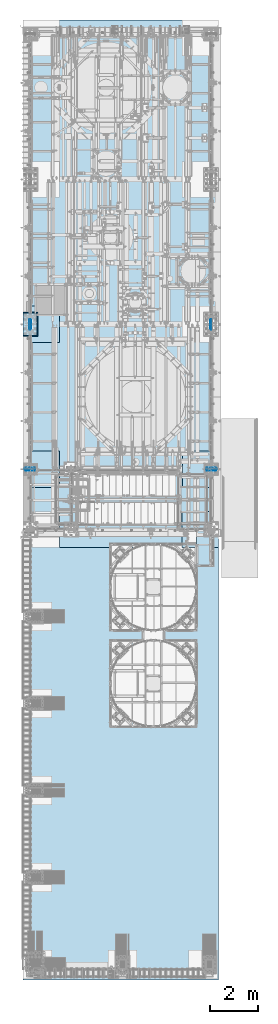
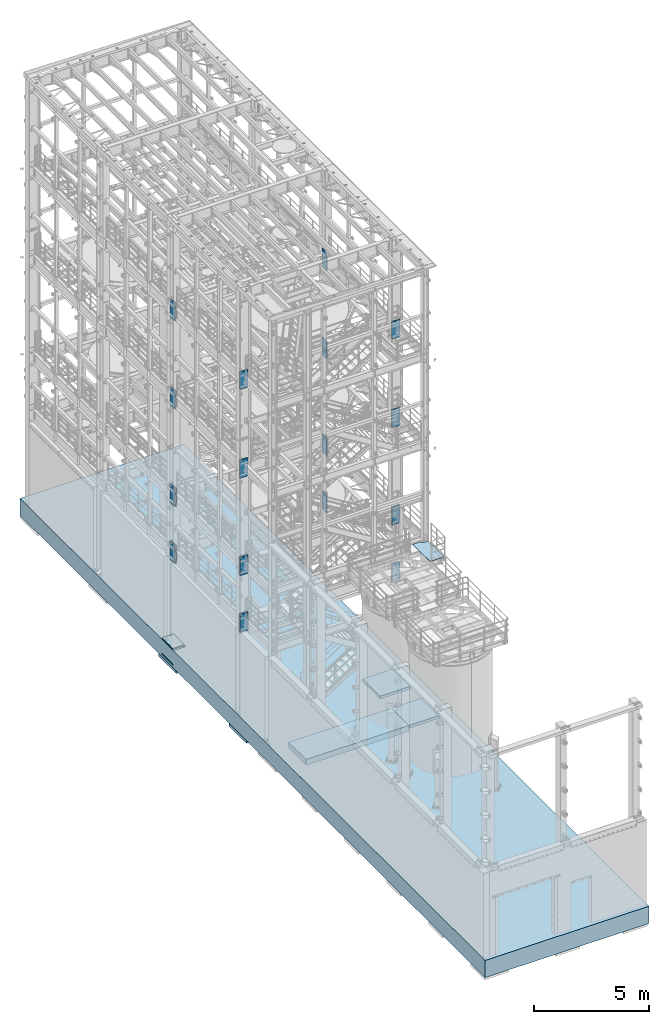
# One storey, part 1402 of 1876: 32 plates, 6 slabs, 17 elements without a shape of their own.
"""IFC2X3 building model written with IfcOpenShell, lengths in millimetres."""

from ifc_helpers import new_model, si_unit, frame, origin_with_axes, place, context, subcontext, project, spatial, faceted_brep, material, type_object, element, aggregate, save


model = new_model("IFC2X3")

# Units and contexts
model_context = context("Model", 3, precision=1e-05, world=origin_with_axes())
body_context = subcontext(model_context, "Body", "Model", "MODEL_VIEW")
ifc_project = project(units=[si_unit("LENGTHUNIT", "METRE", prefix="MILLI"), si_unit("AREAUNIT", "SQUARE_METRE"), si_unit("VOLUMEUNIT", "CUBIC_METRE"), si_unit("MASSUNIT", "GRAM", prefix="KILO"), si_unit("TIMEUNIT", "SECOND"), si_unit("PLANEANGLEUNIT", "RADIAN"), si_unit("SOLIDANGLEUNIT", "STERADIAN"), si_unit("THERMODYNAMICTEMPERATUREUNIT", "DEGREE_CELSIUS"), si_unit("LUMINOUSINTENSITYUNIT", "LUMEN")], contexts=[model_context])

# Site, building, storey
site_placement = place(None, origin_with_axes())
site = spatial("IfcSite", under=ifc_project, at=site_placement, CompositionType="ELEMENT")
building_placement = place(site_placement, origin_with_axes())
building = spatial("IfcBuilding", under=site, at=building_placement, Name="Undefined", CompositionType="ELEMENT")
storey_placement = place(building_placement, origin_with_axes())
storey = spatial("IfcBuildingStorey", under=building, at=storey_placement, Name="Undefined", CompositionType="ELEMENT", Elevation=0.0)

# Assembly, plate
assembly_1_placement = place(storey_placement, origin_with_axes())
assembly_1 = element("IfcElementAssembly", 1, at=assembly_1_placement, inside=storey, Name="GRATING", AssemblyPlace="NOTDEFINED", PredefinedType="NOTDEFINED")
ifc_material_1 = material(Name="1")
plate_type_1 = type_object("IfcPlateType", PredefinedType="NOTDEFINED")
plate_1_placement = place(assembly_1_placement, frame((6578.59999849915, -7131.05000084073, 8010.525), z_axis=(1.0, 0.0, 0.0), x_axis=(0.0, -1.0, 0.0)))
plate_1 = element("IfcPlate", 2, at=plate_1_placement, type_object=plate_type_1, material=ifc_material_1, Name="GRATING", context=body_context, shape_type="Brep", body=[
    faceted_brep([(1.23319387057563e-06, -12.6999999999998, 808.037475585938), (69.8499984741384, -12.6999999999998, 808.037475585936), (69.8499984741384, 12.6999999999998, 808.037475585936), (1.23319387057563e-06, 12.6999999999998, 808.037475585938), (69.8499984741393, -12.6999999999998, 893.762512207029), (69.8499984741393, 12.6999999999998, 893.762512207029), (123.82499694826, -12.6999999999998, 893.762512207029), (123.82499694826, 12.6999999999998, 893.762512207029), (123.824996948266, -12.6999999999998, 1123.95007324218), (123.824996948266, 12.6999999999998, 1123.95007324218), (1498.59997558596, -12.6999999999998, 1123.95007324216), (1498.59997558596, 12.6999999999998, 1123.95007324216), (1498.59997558595, -12.6999999999998, 425.451873779265), (1498.59997558595, 12.6999999999998, 425.451873779265), (584.164367675789, -12.6999999999998, 425.451873779284), (584.164367675789, 12.6999999999998, 425.451873779284), (6.49306457489729e-07, 12.6999999999998, 425.451874947612), (6.49306457489729e-07, -12.6999999999998, 425.451874947612)], [[[0, 1, 2, 3]], [[1, 4, 5, 2]], [[4, 6, 7, 5]], [[6, 8, 9, 7]], [[8, 10, 11, 9]], [[10, 12, 13, 11]], [[12, 14, 15, 13]], [[3, 2, 5, 7, 9, 11, 13, 15, 16]], [[0, 3, 16, 17]], [[12, 10, 8, 6, 4, 1, 0, 17, 14]], [[16, 15, 14, 17]]]),
])
aggregate(assembly_1, [plate_1])

# Assembly, slab
assembly_2_placement = place(storey_placement, origin_with_axes())
assembly_2 = element("IfcElementAssembly", 3, at=assembly_2_placement, inside=storey, Name="SLAB", AssemblyPlace="NOTDEFINED", PredefinedType="REINFORCEMENT_UNIT")
ifc_material_2 = material(Name="CONCRETE/3000")
slab_type_1 = type_object("IfcSlabType", PredefinedType="NOTDEFINED")
slab_1_placement = place(assembly_2_placement, frame((6388.0998046875, -6350.0, -1066.8), z_axis=(0.0, -1.0, 0.0), x_axis=(-1.0, 0.0, 0.0)))
slab_1 = element("IfcSlab", 4, at=slab_1_placement, type_object=slab_type_1, material=ifc_material_2, Name="SLAB", PredefinedType="FLOOR", context=body_context, shape_type="Brep", body=[
    faceted_brep([(0.0, -152.4, 0.0), (9.09494701772928e-13, -152.4, 1524.0), (9.09494701772928e-13, 152.4, 1524.0), (0.0, 152.4, 0.0), (5156.19970703125, -152.4, 1524.0), (5156.19970703125, 152.4, 1524.0), (5156.19970703125, -152.4, 0.0), (5156.19970703125, 152.4, 0.0)], [[[0, 1, 2, 3]], [[1, 4, 5, 2]], [[4, 6, 7, 5]], [[6, 0, 3, 7]], [[5, 7, 3, 2]], [[6, 4, 1, 0]]]),
])
aggregate(assembly_2, [slab_1])

# Assembly, plate
assembly_3_placement = place(storey_placement, origin_with_axes())
assembly_3 = element("IfcElementAssembly", 5, at=assembly_3_placement, inside=storey, Name="COLUMN", AssemblyPlace="NOTDEFINED", PredefinedType="RIGID_FRAME")
ifc_material_3 = material(Name="STEEL/A572-GR.50")
plate_type_2 = type_object("IfcPlateType", PredefinedType="NOTDEFINED")
plate_2_placement = place(assembly_3_placement, frame((-219.075, -4541.04375, 13462.0), z_axis=(1.0, 0.0, 0.0), x_axis=(0.0, 0.0, -1.0)))
plate_2 = element("IfcPlate", 6, at=plate_2_placement, type_object=plate_type_2, material=ifc_material_3, Name="PLATE", context=body_context, shape_type="Brep", body=[
    faceted_brep([(0.0, 19.0500000000002, 416.152954742277), (0.0, -19.0500000000002, 438.149993896484), (952.5, -19.0500000000002, 438.149993896484), (952.5, 19.0500000000002, 416.152954742277), (952.5, 19.0500000000002, 21.9970452577367), (0.0, 19.0500000000002, 21.9970452577367), (0.0, -19.0500000000002, 0.0), (952.5, -19.0500000000002, 0.0)], [[[0, 1, 2, 3]], [[0, 3, 4, 5]], [[1, 0, 5, 6]], [[2, 1, 6, 7]], [[3, 2, 7, 4]], [[6, 5, 4, 7]]]),
])

assembly_4_placement = place(storey_placement, origin_with_axes())
assembly_4 = element("IfcElementAssembly", 7, at=assembly_4_placement, inside=storey, Name="COLUMN", AssemblyPlace="NOTDEFINED", PredefinedType="RIGID_FRAME")
plate_3_placement = place(assembly_4_placement, frame((7400.925, -4541.04375, 13462.0), z_axis=(1.0, 0.0, 0.0), x_axis=(0.0, 0.0, -1.0)))
plate_3 = element("IfcPlate", 8, at=plate_3_placement, type_object=plate_type_2, material=ifc_material_3, Name="PLATE", context=body_context, shape_type="Brep", body=[
    faceted_brep([(0.0, 19.0500000000002, 416.152954742277), (0.0, -19.0500000000002, 438.149993896484), (952.5, -19.0500000000002, 438.149993896484), (952.5, 19.0500000000002, 416.152954742277), (952.5, 19.0500000000002, 21.9970452577367), (0.0, 19.0500000000002, 21.9970452577367), (0.0, -19.0500000000002, 0.0), (952.5, -19.0500000000002, 0.0)], [[[0, 1, 2, 3]], [[0, 3, 4, 5]], [[1, 0, 5, 6]], [[2, 1, 6, 7]], [[3, 2, 7, 4]], [[6, 5, 4, 7]]]),
])

# Assembly, plates
assembly_5_placement = place(storey_placement, origin_with_axes())
assembly_5 = element("IfcElementAssembly", 9, at=assembly_5_placement, inside=storey, Name="COLUMN", AssemblyPlace="NOTDEFINED", PredefinedType="RIGID_FRAME")
plate_4_placement = place(assembly_5_placement, frame((-219.075, -4541.04375, 18135.6), z_axis=(1.0, 0.0, 0.0), x_axis=(0.0, 0.0, -1.0)))
plate_4 = element("IfcPlate", 10, at=plate_4_placement, type_object=plate_type_2, material=ifc_material_3, Name="PLATE", context=body_context, shape_type="Brep", body=[
    faceted_brep([(0.0, 19.0500000000002, 416.152954742277), (0.0, -19.0500000000002, 438.149993896484), (920.75, -19.0500000000002, 438.149993896484), (920.75, 19.0500000000002, 416.152954742198), (920.75, 19.0500000000002, 21.9970452577326), (0.0, 19.0500000000002, 21.9970452577367), (0.0, -19.0500000000002, 0.0), (920.75, -19.0500000000002, 0.0)], [[[0, 1, 2, 3]], [[0, 3, 4, 5]], [[1, 0, 5, 6]], [[2, 1, 6, 7]], [[3, 2, 7, 4]], [[6, 5, 4, 7]]]),
])
plate_5_placement = place(assembly_5_placement, frame((-219.075, -4602.95625, 18135.6), z_axis=(1.0, 0.0, 0.0), x_axis=(0.0, 0.0, -1.0)))
plate_5 = element("IfcPlate", 11, at=plate_5_placement, type_object=plate_type_2, material=ifc_material_3, Name="PLATE", context=body_context, shape_type="Brep", body=[
    faceted_brep([(0.0, -19.0500000000002, 416.152954749452), (920.75, -19.0500000000002, 416.152954749452), (920.75, 19.0500000000002, 438.149993896484), (0.0, 19.0500000000002, 438.149993896484), (920.75, -19.0500000000002, 21.9970452506512), (920.75, 19.0500000000002, 0.0), (-9.09494701772928e-13, 19.05, -1.81898940354586e-12), (0.0, -19.0500000000002, 21.9970452506512)], [[[0, 1, 2, 3]], [[2, 1, 4, 5]], [[3, 2, 5, 6]], [[0, 3, 6, 7]], [[1, 0, 7, 4]], [[6, 5, 4, 7]]]),
])
aggregate(assembly_5, [plate_4, plate_5])

assembly_6_placement = place(storey_placement, origin_with_axes())
assembly_6 = element("IfcElementAssembly", 12, at=assembly_6_placement, inside=storey, Name="COLUMN", AssemblyPlace="NOTDEFINED", PredefinedType="RIGID_FRAME")
plate_6_placement = place(assembly_6_placement, frame((7400.925, -4541.04375, 18135.6), z_axis=(1.0, 0.0, 0.0), x_axis=(0.0, 0.0, -1.0)))
plate_6 = element("IfcPlate", 13, at=plate_6_placement, type_object=plate_type_2, material=ifc_material_3, Name="PLATE", context=body_context, shape_type="Brep", body=[
    faceted_brep([(0.0, 19.0500000000002, 416.152954742277), (0.0, -19.0500000000002, 438.149993896484), (920.75, -19.0500000000002, 438.149993896484), (920.75, 19.0500000000002, 416.152954742198), (920.75, 19.0500000000002, 21.9970452577326), (0.0, 19.0500000000002, 21.9970452577367), (0.0, -19.0500000000002, 0.0), (920.75, -19.0500000000002, 0.0)], [[[0, 1, 2, 3]], [[0, 3, 4, 5]], [[1, 0, 5, 6]], [[2, 1, 6, 7]], [[3, 2, 7, 4]], [[6, 5, 4, 7]]]),
])
plate_7_placement = place(assembly_6_placement, frame((7400.925, -4602.95625, 18135.6), z_axis=(1.0, 0.0, 0.0), x_axis=(0.0, 0.0, -1.0)))
plate_7 = element("IfcPlate", 14, at=plate_7_placement, type_object=plate_type_2, material=ifc_material_3, Name="PLATE", context=body_context, shape_type="Brep", body=[
    faceted_brep([(0.0, -19.0500000000002, 416.152954749452), (920.75, -19.0500000000002, 416.152954749452), (920.75, 19.0500000000002, 438.149993896484), (0.0, 19.0500000000002, 438.149993896484), (920.75, -19.0500000000002, 21.9970452506512), (920.75, 19.0500000000002, 0.0), (-9.09494701772928e-13, 19.05, -1.81898940354586e-12), (0.0, -19.0500000000002, 21.9970452506512)], [[[0, 1, 2, 3]], [[2, 1, 4, 5]], [[3, 2, 5, 6]], [[0, 3, 6, 7]], [[1, 0, 7, 4]], [[6, 5, 4, 7]]]),
])
aggregate(assembly_6, [plate_6, plate_7])

# Assembly, plate
assembly_7_placement = place(storey_placement, origin_with_axes())
assembly_7 = element("IfcElementAssembly", 15, at=assembly_7_placement, inside=storey, Name="COLUMN", AssemblyPlace="NOTDEFINED", PredefinedType="RIGID_FRAME")
plate_8_placement = place(assembly_7_placement, frame((7590.63125, 1304.925, 18135.6), z_axis=(0.0, 1.0, 0.0), x_axis=(0.0, 0.0, -1.0)))
plate_8 = element("IfcPlate", 16, at=plate_8_placement, type_object=plate_type_2, material=ifc_material_3, Name="PLATE", context=body_context, shape_type="Brep", body=[
    faceted_brep([(0.0, 19.0500000000002, 416.152954742277), (0.0, -19.0500000000002, 438.149993896484), (952.5, -19.0500000000002, 438.149993896484), (952.5, 19.0500000000002, 416.152954742277), (952.5, 19.0500000000002, 21.9970452577367), (0.0, 19.0500000000002, 21.9970452577367), (0.0, -19.0500000000002, 0.0), (952.5, -19.0500000000002, 0.0)], [[[0, 1, 2, 3]], [[0, 3, 4, 5]], [[1, 0, 5, 6]], [[2, 1, 6, 7]], [[3, 2, 7, 4]], [[6, 5, 4, 7]]]),
])
aggregate(assembly_7, [plate_8])

# Assembly, plates
assembly_8_placement = place(storey_placement, origin_with_axes())
assembly_8 = element("IfcElementAssembly", 17, at=assembly_8_placement, inside=storey, Name="COLUMN", AssemblyPlace="NOTDEFINED", PredefinedType="RIGID_FRAME")
plate_9_placement = place(assembly_8_placement, frame((29.3687499999999, 1743.075, 18135.6), z_axis=(0.0, -1.0, 0.0), x_axis=(0.0, 0.0, -1.0)))
plate_9 = element("IfcPlate", 18, at=plate_9_placement, type_object=plate_type_2, material=ifc_material_3, Name="PLATE", context=body_context, shape_type="Brep", body=[
    faceted_brep([(0.0, 19.0500000000002, 416.152954742277), (0.0, -19.0500000000002, 438.149993896484), (952.5, -19.0500000000002, 438.149993896484), (952.5, 19.0500000000002, 416.152954742277), (952.5, 19.0500000000002, 21.9970452577367), (0.0, 19.0500000000002, 21.9970452577367), (0.0, -19.0500000000002, 0.0), (952.5, -19.0500000000002, 0.0)], [[[0, 1, 2, 3]], [[0, 3, 4, 5]], [[1, 0, 5, 6]], [[2, 1, 6, 7]], [[3, 2, 7, 4]], [[6, 5, 4, 7]]]),
])
plate_10_placement = place(assembly_8_placement, frame((-29.3687499999999, 1743.075, 18135.6), z_axis=(0.0, -1.0, 0.0), x_axis=(0.0, 0.0, -1.0)))
plate_10 = element("IfcPlate", 19, at=plate_10_placement, type_object=plate_type_2, material=ifc_material_3, Name="PLATE", context=body_context, shape_type="Brep", body=[
    faceted_brep([(0.0, -19.0500000000002, 416.152954749452), (952.5, -19.0500000000002, 416.152954749464), (952.5, 19.0500000000002, 438.149993896484), (0.0, 19.0500000000002, 438.149993896484), (952.5, -19.0500000000002, 21.997045250647), (952.5, 19.0500000000002, 0.0), (-9.09494701772928e-13, 19.05, -1.81898940354586e-12), (0.0, -19.0500000000002, 21.9970452506512)], [[[0, 1, 2, 3]], [[2, 1, 4, 5]], [[3, 2, 5, 6]], [[0, 3, 6, 7]], [[1, 0, 7, 4]], [[6, 5, 4, 7]]]),
])
aggregate(assembly_8, [plate_9, plate_10])

assembly_9_placement = place(storey_placement, origin_with_axes())
assembly_9 = element("IfcElementAssembly", 20, at=assembly_9_placement, inside=storey, Name="COLUMN", AssemblyPlace="NOTDEFINED", PredefinedType="RIGID_FRAME")
plate_11_placement = place(assembly_9_placement, frame((29.3687499999999, 1743.075, 13462.0), z_axis=(0.0, -1.0, 0.0), x_axis=(0.0, 0.0, -1.0)))
plate_11 = element("IfcPlate", 21, at=plate_11_placement, type_object=plate_type_2, material=ifc_material_3, Name="PLATE", context=body_context, shape_type="Brep", body=[
    faceted_brep([(0.0, 19.0500000000002, 416.152954742277), (0.0, -19.0500000000002, 438.149993896484), (952.5, -19.0500000000002, 438.149993896484), (952.5, 19.0500000000002, 416.152954742277), (952.5, 19.0500000000002, 21.9970452577367), (0.0, 19.0500000000002, 21.9970452577367), (0.0, -19.0500000000002, 0.0), (952.5, -19.0500000000002, 0.0)], [[[0, 1, 2, 3]], [[0, 3, 4, 5]], [[1, 0, 5, 6]], [[2, 1, 6, 7]], [[3, 2, 7, 4]], [[6, 5, 4, 7]]]),
])
plate_12_placement = place(assembly_9_placement, frame((-29.3687499999999, 1743.075, 13462.0), z_axis=(0.0, -1.0, 0.0), x_axis=(0.0, 0.0, -1.0)))
plate_12 = element("IfcPlate", 22, at=plate_12_placement, type_object=plate_type_2, material=ifc_material_3, Name="PLATE", context=body_context, shape_type="Brep", body=[
    faceted_brep([(0.0, -19.0500000000002, 416.152954749452), (952.5, -19.0500000000002, 416.152954749464), (952.5, 19.0500000000002, 438.149993896484), (0.0, 19.0500000000002, 438.149993896484), (952.5, -19.0500000000002, 21.997045250647), (952.5, 19.0500000000002, 0.0), (-9.09494701772928e-13, 19.05, -1.81898940354586e-12), (0.0, -19.0500000000002, 21.9970452506512)], [[[0, 1, 2, 3]], [[2, 1, 4, 5]], [[3, 2, 5, 6]], [[0, 3, 6, 7]], [[1, 0, 7, 4]], [[6, 5, 4, 7]]]),
])
plate_13_placement = place(assembly_9_placement, frame((29.3687499999999, 1743.075, 8305.8), z_axis=(0.0, -1.0, 0.0), x_axis=(0.0, 0.0, -1.0)))
plate_13 = element("IfcPlate", 23, at=plate_13_placement, type_object=plate_type_2, material=ifc_material_3, Name="PLATE", context=body_context, shape_type="Brep", body=[
    faceted_brep([(0.0, 19.0500000000002, 416.152954742277), (0.0, -19.0500000000002, 438.149993896484), (952.5, -19.0500000000002, 438.149993896484), (952.5, 19.0500000000002, 416.152954742277), (952.5, 19.0500000000002, 21.9970452577367), (0.0, 19.0500000000002, 21.9970452577367), (0.0, -19.0500000000002, 0.0), (952.5, -19.0500000000002, 0.0)], [[[0, 1, 2, 3]], [[0, 3, 4, 5]], [[1, 0, 5, 6]], [[2, 1, 6, 7]], [[3, 2, 7, 4]], [[6, 5, 4, 7]]]),
])
plate_14_placement = place(assembly_9_placement, frame((-29.3687499999999, 1743.075, 8305.8), z_axis=(0.0, -1.0, 0.0), x_axis=(0.0, 0.0, -1.0)))
plate_14 = element("IfcPlate", 24, at=plate_14_placement, type_object=plate_type_2, material=ifc_material_3, Name="PLATE", context=body_context, shape_type="Brep", body=[
    faceted_brep([(0.0, -19.0500000000002, 416.152954749452), (952.5, -19.0500000000002, 416.152954749464), (952.5, 19.0500000000002, 438.149993896484), (0.0, 19.0500000000002, 438.149993896484), (952.5, -19.0500000000002, 21.997045250647), (952.5, 19.0500000000002, 0.0), (-9.09494701772928e-13, 19.05, -1.81898940354586e-12), (0.0, -19.0500000000002, 21.9970452506512)], [[[0, 1, 2, 3]], [[2, 1, 4, 5]], [[3, 2, 5, 6]], [[0, 3, 6, 7]], [[1, 0, 7, 4]], [[6, 5, 4, 7]]]),
])

# Plate
plate_15_placement = place(assembly_4_placement, frame((7400.925, -4602.95625, 13462.0), z_axis=(1.0, 0.0, 0.0), x_axis=(0.0, 0.0, -1.0)))
plate_15 = element("IfcPlate", 25, at=plate_15_placement, type_object=plate_type_2, material=ifc_material_3, Name="PLATE", context=body_context, shape_type="Brep", body=[
    faceted_brep([(0.0, -19.0500000000002, 416.152954749452), (952.5, -19.0500000000002, 416.152954749464), (952.5, 19.0500000000002, 438.149993896484), (0.0, 19.0500000000002, 438.149993896484), (952.5, -19.0500000000002, 21.997045250647), (952.5, 19.0500000000002, 0.0), (-9.09494701772928e-13, 19.05, -1.81898940354586e-12), (0.0, -19.0500000000002, 21.9970452506512)], [[[0, 1, 2, 3]], [[2, 1, 4, 5]], [[3, 2, 5, 6]], [[0, 3, 6, 7]], [[1, 0, 7, 4]], [[6, 5, 4, 7]]]),
])

plate_16_placement = place(assembly_3_placement, frame((-219.075, -4602.95625, 13462.0), z_axis=(1.0, 0.0, 0.0), x_axis=(0.0, 0.0, -1.0)))
plate_16 = element("IfcPlate", 26, at=plate_16_placement, type_object=plate_type_2, material=ifc_material_3, Name="PLATE", context=body_context, shape_type="Brep", body=[
    faceted_brep([(0.0, -19.0500000000002, 416.152954749452), (952.5, -19.0500000000002, 416.152954749464), (952.5, 19.0500000000002, 438.149993896484), (0.0, 19.0500000000002, 438.149993896484), (952.5, -19.0500000000002, 21.997045250647), (952.5, 19.0500000000002, 0.0), (-9.09494701772928e-13, 19.05, -1.81898940354586e-12), (0.0, -19.0500000000002, 21.9970452506512)], [[[0, 1, 2, 3]], [[2, 1, 4, 5]], [[3, 2, 5, 6]], [[0, 3, 6, 7]], [[1, 0, 7, 4]], [[6, 5, 4, 7]]]),
])

# Assembly, plates
assembly_10_placement = place(storey_placement, origin_with_axes())
assembly_10 = element("IfcElementAssembly", 27, at=assembly_10_placement, inside=storey, Name="COLUMN", AssemblyPlace="NOTDEFINED", PredefinedType="RIGID_FRAME")
plate_17_placement = place(assembly_10_placement, frame((7590.63125, 1304.925, 13462.0), z_axis=(0.0, 1.0, 0.0), x_axis=(0.0, 0.0, -1.0)))
plate_17 = element("IfcPlate", 28, at=plate_17_placement, type_object=plate_type_2, material=ifc_material_3, Name="PLATE", context=body_context, shape_type="Brep", body=[
    faceted_brep([(0.0, 19.0500000000002, 416.152954742277), (0.0, -19.0500000000002, 438.149993896484), (952.5, -19.0500000000002, 438.149993896484), (952.5, 19.0500000000002, 416.152954742277), (952.5, 19.0500000000002, 21.9970452577367), (0.0, 19.0500000000002, 21.9970452577367), (0.0, -19.0500000000002, 0.0), (952.5, -19.0500000000002, 0.0)], [[[0, 1, 2, 3]], [[0, 3, 4, 5]], [[1, 0, 5, 6]], [[2, 1, 6, 7]], [[3, 2, 7, 4]], [[6, 5, 4, 7]]]),
])
plate_18_placement = place(assembly_10_placement, frame((7590.63125, 1304.925, 8305.8), z_axis=(0.0, 1.0, 0.0), x_axis=(0.0, 0.0, -1.0)))
plate_18 = element("IfcPlate", 29, at=plate_18_placement, type_object=plate_type_2, material=ifc_material_3, Name="PLATE", context=body_context, shape_type="Brep", body=[
    faceted_brep([(0.0, 19.0500000000002, 416.152954742277), (0.0, -19.0500000000002, 438.149993896484), (952.5, -19.0500000000002, 438.149993896484), (952.5, 19.0500000000002, 416.152954742277), (952.5, 19.0500000000002, 21.9970452577367), (0.0, 19.0500000000002, 21.9970452577367), (0.0, -19.0500000000002, 0.0), (952.5, -19.0500000000002, 0.0)], [[[0, 1, 2, 3]], [[0, 3, 4, 5]], [[1, 0, 5, 6]], [[2, 1, 6, 7]], [[3, 2, 7, 4]], [[6, 5, 4, 7]]]),
])
plate_19_placement = place(assembly_10_placement, frame((7590.63125, 1304.925, 5283.2), z_axis=(0.0, 1.0, 0.0), x_axis=(0.0, 0.0, -1.0)))
plate_19 = element("IfcPlate", 30, at=plate_19_placement, type_object=plate_type_2, material=ifc_material_3, Name="PLATE", context=body_context, shape_type="Brep", body=[
    faceted_brep([(0.0, 19.0500000000002, 416.152954742277), (0.0, -19.0500000000002, 438.149993896484), (952.5, -19.0500000000002, 438.149993896484), (952.5, 19.0500000000002, 416.152954742277), (952.5, 19.0500000000002, 21.9970452577367), (0.0, 19.0500000000002, 21.9970452577367), (0.0, -19.0500000000002, 0.0), (952.5, -19.0500000000002, 0.0)], [[[0, 1, 2, 3]], [[0, 3, 4, 5]], [[1, 0, 5, 6]], [[2, 1, 6, 7]], [[3, 2, 7, 4]], [[6, 5, 4, 7]]]),
])
aggregate(assembly_10, [plate_17, plate_18, plate_19])

# Plate
plate_20_placement = place(assembly_9_placement, frame((29.3687499999999, 1743.075, 5283.2), z_axis=(0.0, -1.0, 0.0), x_axis=(0.0, 0.0, -1.0)))
plate_20 = element("IfcPlate", 31, at=plate_20_placement, type_object=plate_type_2, material=ifc_material_3, Name="PLATE", context=body_context, shape_type="Brep", body=[
    faceted_brep([(0.0, 19.0500000000002, 416.152954742277), (0.0, -19.0500000000002, 438.149993896484), (952.5, -19.0500000000002, 438.149993896484), (952.5, 19.0500000000002, 416.152954742277), (952.5, 19.0500000000002, 21.9970452577367), (0.0, 19.0500000000002, 21.9970452577367), (0.0, -19.0500000000002, 0.0), (952.5, -19.0500000000002, 0.0)], [[[0, 1, 2, 3]], [[0, 3, 4, 5]], [[1, 0, 5, 6]], [[2, 1, 6, 7]], [[3, 2, 7, 4]], [[6, 5, 4, 7]]]),
])

plate_21_placement = place(assembly_9_placement, frame((-29.3687499999999, 1743.075, 5283.2), z_axis=(0.0, -1.0, 0.0), x_axis=(0.0, 0.0, -1.0)))
plate_21 = element("IfcPlate", 32, at=plate_21_placement, type_object=plate_type_2, material=ifc_material_3, Name="PLATE", context=body_context, shape_type="Brep", body=[
    faceted_brep([(0.0, -19.0500000000002, 416.152954749452), (952.5, -19.0500000000002, 416.152954749464), (952.5, 19.0500000000002, 438.149993896484), (0.0, 19.0500000000002, 438.149993896484), (952.5, -19.0500000000002, 21.997045250647), (952.5, 19.0500000000002, 0.0), (-9.09494701772928e-13, 19.05, -1.81898940354586e-12), (0.0, -19.0500000000002, 21.9970452506512)], [[[0, 1, 2, 3]], [[2, 1, 4, 5]], [[3, 2, 5, 6]], [[0, 3, 6, 7]], [[1, 0, 7, 4]], [[6, 5, 4, 7]]]),
])

plate_type_3 = type_object("IfcPlateType", PredefinedType="NOTDEFINED")
plate_22_placement = place(assembly_3_placement, frame((-219.075, -4537.86875, 8305.8), z_axis=(1.0, 0.0, 0.0), x_axis=(0.0, 0.0, -1.0)))
plate_22 = element("IfcPlate", 33, at=plate_22_placement, type_object=plate_type_3, material=ifc_material_3, Name="PLATE", context=body_context, shape_type="Brep", body=[
    faceted_brep([(0.0, 22.2250000000004, 412.486780532837), (0.0, -22.2250000000004, 438.149993896484), (952.5, -22.2250000000004, 438.149993896484), (952.5, 22.2250000000004, 412.486780532837), (952.5, 22.2250000000004, 25.663219467172), (0.0, 22.2250000000004, 25.663219467172), (0.0, -22.2250000000004, 0.0), (952.5, -22.2250000000004, 0.0)], [[[0, 1, 2, 3]], [[0, 3, 4, 5]], [[1, 0, 5, 6]], [[2, 1, 6, 7]], [[3, 2, 7, 4]], [[6, 5, 4, 7]]]),
])

plate_23_placement = place(assembly_3_placement, frame((-219.075, -4606.13125, 8305.8), z_axis=(1.0, 0.0, 0.0), x_axis=(0.0, 0.0, -1.0)))
plate_23 = element("IfcPlate", 34, at=plate_23_placement, type_object=plate_type_3, material=ifc_material_3, Name="PLATE", context=body_context, shape_type="Brep", body=[
    faceted_brep([(0.0, -22.2250000000004, 412.486780540907), (952.5, -22.2250000000004, 412.486780540907), (952.5, 22.2250000000004, 438.149993896484), (0.0, 22.2250000000004, 438.149993896484), (952.5, -22.2250000000004, 25.6632194590944), (952.5, 22.2250000000004, 0.0), (0.0, 22.2250000000004, 0.0), (0.0, -22.2250000000004, 25.6632194590944)], [[[0, 1, 2, 3]], [[2, 1, 4, 5]], [[3, 2, 5, 6]], [[0, 3, 6, 7]], [[1, 0, 7, 4]], [[6, 5, 4, 7]]]),
])

plate_24_placement = place(assembly_4_placement, frame((7400.925, -4537.86875, 8305.8), z_axis=(1.0, 0.0, 0.0), x_axis=(0.0, 0.0, -1.0)))
plate_24 = element("IfcPlate", 35, at=plate_24_placement, type_object=plate_type_3, material=ifc_material_3, Name="PLATE", context=body_context, shape_type="Brep", body=[
    faceted_brep([(0.0, 22.2250000000004, 412.486780532837), (0.0, -22.2250000000004, 438.149993896484), (952.5, -22.2250000000004, 438.149993896484), (952.5, 22.2250000000004, 412.486780532837), (952.5, 22.2250000000004, 25.663219467172), (0.0, 22.2250000000004, 25.663219467172), (0.0, -22.2250000000004, 0.0), (952.5, -22.2250000000004, 0.0)], [[[0, 1, 2, 3]], [[0, 3, 4, 5]], [[1, 0, 5, 6]], [[2, 1, 6, 7]], [[3, 2, 7, 4]], [[6, 5, 4, 7]]]),
])

plate_25_placement = place(assembly_4_placement, frame((7400.925, -4606.13125, 8305.8), z_axis=(1.0, 0.0, 0.0), x_axis=(0.0, 0.0, -1.0)))
plate_25 = element("IfcPlate", 36, at=plate_25_placement, type_object=plate_type_3, material=ifc_material_3, Name="PLATE", context=body_context, shape_type="Brep", body=[
    faceted_brep([(0.0, -22.2250000000004, 412.486780540907), (952.5, -22.2250000000004, 412.486780540907), (952.5, 22.2250000000004, 438.149993896484), (0.0, 22.2250000000004, 438.149993896484), (952.5, -22.2250000000004, 25.6632194590944), (952.5, 22.2250000000004, 0.0), (0.0, 22.2250000000004, 0.0), (0.0, -22.2250000000004, 25.6632194590944)], [[[0, 1, 2, 3]], [[2, 1, 4, 5]], [[3, 2, 5, 6]], [[0, 3, 6, 7]], [[1, 0, 7, 4]], [[6, 5, 4, 7]]]),
])

plate_26_placement = place(assembly_4_placement, frame((7400.925, -4537.86875, 5283.2), z_axis=(1.0, 0.0, 0.0), x_axis=(0.0, 0.0, -1.0)))
plate_26 = element("IfcPlate", 37, at=plate_26_placement, type_object=plate_type_3, material=ifc_material_3, Name="PLATE", context=body_context, shape_type="Brep", body=[
    faceted_brep([(0.0, 22.2250000000004, 412.486780532837), (0.0, -22.2250000000004, 438.149993896484), (952.5, -22.2250000000004, 438.149993896484), (952.5, 22.2250000000004, 412.486780532837), (952.5, 22.2250000000004, 25.663219467172), (0.0, 22.2250000000004, 25.663219467172), (0.0, -22.2250000000004, 0.0), (952.5, -22.2250000000004, 0.0)], [[[0, 1, 2, 3]], [[0, 3, 4, 5]], [[1, 0, 5, 6]], [[2, 1, 6, 7]], [[3, 2, 7, 4]], [[6, 5, 4, 7]]]),
])

plate_27_placement = place(assembly_4_placement, frame((7400.925, -4606.13125, 5283.2), z_axis=(1.0, 0.0, 0.0), x_axis=(0.0, 0.0, -1.0)))
plate_27 = element("IfcPlate", 38, at=plate_27_placement, type_object=plate_type_3, material=ifc_material_3, Name="PLATE", context=body_context, shape_type="Brep", body=[
    faceted_brep([(0.0, -22.2250000000004, 412.486780540907), (952.5, -22.2250000000004, 412.486780540907), (952.5, 22.2250000000004, 438.149993896484), (0.0, 22.2250000000004, 438.149993896484), (952.5, -22.2250000000004, 25.6632194590944), (952.5, 22.2250000000004, 0.0), (0.0, 22.2250000000004, 0.0), (0.0, -22.2250000000004, 25.6632194590944)], [[[0, 1, 2, 3]], [[2, 1, 4, 5]], [[3, 2, 5, 6]], [[0, 3, 6, 7]], [[1, 0, 7, 4]], [[6, 5, 4, 7]]]),
])

aggregate(assembly_4, [plate_3, plate_15, plate_24, plate_25, plate_26, plate_27])

plate_28_placement = place(assembly_3_placement, frame((-219.075, -4537.86875, 5283.2), z_axis=(1.0, 0.0, 0.0), x_axis=(0.0, 0.0, -1.0)))
plate_28 = element("IfcPlate", 39, at=plate_28_placement, type_object=plate_type_3, material=ifc_material_3, Name="PLATE", context=body_context, shape_type="Brep", body=[
    faceted_brep([(0.0, 22.2250000000004, 412.486780532837), (0.0, -22.2250000000004, 438.149993896484), (952.5, -22.2250000000004, 438.149993896484), (952.5, 22.2250000000004, 412.486780532837), (952.5, 22.2250000000004, 25.663219467172), (0.0, 22.2250000000004, 25.663219467172), (0.0, -22.2250000000004, 0.0), (952.5, -22.2250000000004, 0.0)], [[[0, 1, 2, 3]], [[0, 3, 4, 5]], [[1, 0, 5, 6]], [[2, 1, 6, 7]], [[3, 2, 7, 4]], [[6, 5, 4, 7]]]),
])

plate_29_placement = place(assembly_3_placement, frame((-219.075, -4606.13125, 5283.2), z_axis=(1.0, 0.0, 0.0), x_axis=(0.0, 0.0, -1.0)))
plate_29 = element("IfcPlate", 40, at=plate_29_placement, type_object=plate_type_3, material=ifc_material_3, Name="PLATE", context=body_context, shape_type="Brep", body=[
    faceted_brep([(0.0, -22.2250000000004, 412.486780540907), (952.5, -22.2250000000004, 412.486780540907), (952.5, 22.2250000000004, 438.149993896484), (0.0, 22.2250000000004, 438.149993896484), (952.5, -22.2250000000004, 25.6632194590944), (952.5, 22.2250000000004, 0.0), (0.0, 22.2250000000004, 0.0), (0.0, -22.2250000000004, 25.6632194590944)], [[[0, 1, 2, 3]], [[2, 1, 4, 5]], [[3, 2, 5, 6]], [[0, 3, 6, 7]], [[1, 0, 7, 4]], [[6, 5, 4, 7]]]),
])

aggregate(assembly_3, [plate_2, plate_16, plate_22, plate_23, plate_28, plate_29])

# Assembly, slab
assembly_11_placement = place(storey_placement, origin_with_axes())
assembly_11 = element("IfcElementAssembly", 41, at=assembly_11_placement, inside=storey, Name="SLAB", AssemblyPlace="NOTDEFINED", PredefinedType="REINFORCEMENT_UNIT")
slab_type_2 = type_object("IfcSlabType", PredefinedType="NOTDEFINED")
slab_2_placement = place(assembly_11_placement, frame((7912.0998046875, -6350.0, -990.6), z_axis=(0.0, -1.0, 0.0), x_axis=(-1.0, 0.0, 0.0)))
slab_2 = element("IfcSlab", 42, at=slab_2_placement, type_object=slab_type_2, material=ifc_material_2, Name="SLAB", PredefinedType="FLOOR", context=body_context, shape_type="Brep", body=[
    faceted_brep([(0.0, -76.2, 0.0), (9.09494701772928e-13, -76.2, 1524.0), (9.09494701772928e-13, 76.2, 1524.0), (0.0, 76.2, 0.0), (1524.0, -76.2, 1524.0), (1524.0, 76.2, 1524.0), (1524.0, -76.2, 0.0), (1524.0, 76.2, 0.0)], [[[0, 1, 2, 3]], [[1, 4, 5, 2]], [[4, 6, 7, 5]], [[6, 0, 3, 7]], [[5, 7, 3, 2]], [[6, 4, 1, 0]]]),
])
aggregate(assembly_11, [slab_2])

assembly_12_placement = place(storey_placement, origin_with_axes())
assembly_12 = element("IfcElementAssembly", 43, at=assembly_12_placement, inside=storey, Name="SLAB", AssemblyPlace="NOTDEFINED", PredefinedType="REINFORCEMENT_UNIT")
slab_3_placement = place(assembly_12_placement, frame((7937.4998046875, -3810.0, -990.6), z_axis=(0.0, -1.0, 0.0), x_axis=(-1.0, 0.0, 0.0)))
slab_3 = element("IfcSlab", 44, at=slab_3_placement, type_object=slab_type_2, material=ifc_material_2, Name="SLAB", PredefinedType="FLOOR", context=body_context, shape_type="Brep", body=[
    faceted_brep([(0.0, -76.2, 0.0), (9.09494701772928e-13, -76.2, 1524.0), (9.09494701772928e-13, 76.2, 1524.0), (0.0, 76.2, 0.0), (1524.0, -76.2, 1524.0), (1524.0, 76.2, 1524.0), (1524.0, -76.2, 0.0), (1524.0, 76.2, 0.0)], [[[0, 1, 2, 3]], [[1, 4, 5, 2]], [[4, 6, 7, 5]], [[6, 0, 3, 7]], [[5, 7, 3, 2]], [[6, 4, 1, 0]]]),
])
aggregate(assembly_12, [slab_3])

assembly_13_placement = place(storey_placement, origin_with_axes())
assembly_13 = element("IfcElementAssembly", 45, at=assembly_13_placement, inside=storey, Name="SLAB", AssemblyPlace="NOTDEFINED", PredefinedType="REINFORCEMENT_UNIT")
slab_4_placement = place(assembly_13_placement, frame((1231.9, -3810.0, -990.6), z_axis=(0.0, -1.0, 0.0), x_axis=(-1.0, 0.0, 0.0)))
slab_4 = element("IfcSlab", 46, at=slab_4_placement, type_object=slab_type_2, material=ifc_material_2, Name="SLAB", PredefinedType="FLOOR", context=body_context, shape_type="Brep", body=[
    faceted_brep([(0.0, -76.2, 0.0), (9.09494701772928e-13, -76.2, 1524.0), (9.09494701772928e-13, 76.2, 1524.0), (0.0, 76.2, 0.0), (1524.0, -76.2, 1524.0), (1524.0, 76.2, 1524.0), (1524.0, -76.2, 0.0), (1524.0, 76.2, 0.0)], [[[0, 1, 2, 3]], [[1, 4, 5, 2]], [[4, 6, 7, 5]], [[6, 0, 3, 7]], [[5, 7, 3, 2]], [[6, 4, 1, 0]]]),
])
aggregate(assembly_13, [slab_4])

assembly_14_placement = place(storey_placement, origin_with_axes())
assembly_14 = element("IfcElementAssembly", 47, at=assembly_14_placement, inside=storey, Name="SLAB", AssemblyPlace="NOTDEFINED", PredefinedType="REINFORCEMENT_UNIT")
slab_5_placement = place(assembly_14_placement, frame((1231.9, 2286.0, -990.6), z_axis=(0.0, -1.0, 0.0), x_axis=(-1.0, 0.0, 0.0)))
slab_5 = element("IfcSlab", 48, at=slab_5_placement, type_object=slab_type_2, material=ifc_material_2, Name="SLAB", PredefinedType="FLOOR", context=body_context, shape_type="Brep", body=[
    faceted_brep([(0.0, -76.2, 0.0), (9.09494701772928e-13, -76.2, 1524.0), (9.09494701772928e-13, 76.2, 1524.0), (0.0, 76.2, 0.0), (1524.0, -76.2, 1524.0), (1524.0, 76.2, 1524.0), (1524.0, -76.2, 0.0), (1524.0, 76.2, 0.0)], [[[0, 1, 2, 3]], [[1, 4, 5, 2]], [[4, 6, 7, 5]], [[6, 0, 3, 7]], [[5, 7, 3, 2]], [[6, 4, 1, 0]]]),
])
aggregate(assembly_14, [slab_5])

# Assembly, plate
assembly_15_placement = place(storey_placement, origin_with_axes())
assembly_15 = element("IfcElementAssembly", 49, at=assembly_15_placement, inside=storey, Name="TEMPLATE", AssemblyPlace="NOTDEFINED", PredefinedType="RIGID_FRAME")
ifc_material_4 = material(Name="STEEL/A572-50")
plate_type_4 = type_object("IfcPlateType", PredefinedType="NOTDEFINED")
plate_30_placement = place(assembly_15_placement, frame((-292.1, 1993.9, -765.175), z_axis=(1.0, 0.0, 0.0), x_axis=(0.0, -1.0, 0.0)))
plate_30 = element("IfcPlate", 50, at=plate_30_placement, type_object=plate_type_4, material=ifc_material_4, Name="PLATE", context=body_context, shape_type="Brep", body=[
    faceted_brep([(0.0, -28.575, 0.0), (0.0, -28.575, 584.200012207031), (0.0, 28.575, 584.200012207031), (0.0, 28.575, 0.0), (939.799987792969, -28.575, 584.200012207031), (939.799987792969, 28.575, 584.200012207031), (939.799987792969, -28.575, 0.0), (939.799987792969, 28.575, 0.0)], [[[0, 1, 2, 3]], [[1, 4, 5, 2]], [[4, 6, 7, 5]], [[6, 0, 3, 7]], [[5, 7, 3, 2]], [[6, 4, 1, 0]]]),
])
aggregate(assembly_15, [plate_30])

# Plate
plate_31_placement = place(assembly_9_placement, frame((-292.1, 1993.9, 66.675), z_axis=(1.0, 0.0, 0.0), x_axis=(0.0, -1.0, 0.0)))
plate_31 = element("IfcPlate", 51, at=plate_31_placement, type_object=plate_type_4, material=ifc_material_3, Name="PLATE", context=body_context, shape_type="Brep", body=[
    faceted_brep([(0.0, -28.575, 0.0), (0.0, -28.575, 584.200012207031), (0.0, 28.575, 584.200012207031), (0.0, 28.575, 0.0), (939.799987792969, -28.575, 584.200012207031), (939.799987792969, 28.575, 584.200012207031), (939.799987792969, -28.575, 0.0), (939.799987792969, 28.575, 0.0)], [[[0, 1, 2, 3]], [[1, 4, 5, 2]], [[4, 6, 7, 5]], [[6, 0, 3, 7]], [[5, 7, 3, 2]], [[6, 4, 1, 0]]]),
])

aggregate(assembly_9, [plate_11, plate_12, plate_13, plate_14, plate_20, plate_21, plate_31])

# Assembly, plate
assembly_16_placement = place(storey_placement, origin_with_axes())
assembly_16 = element("IfcElementAssembly", 52, at=assembly_16_placement, inside=storey, Name="GROUT", AssemblyPlace="NOTDEFINED", PredefinedType="REINFORCEMENT_UNIT")
ifc_material_5 = material(Name="CONCRETE/Concrete_Undefined")
plate_type_5 = type_object("IfcPlateType", PredefinedType="NOTDEFINED")
plate_32_placement = place(assembly_16_placement, frame((-330.2, 2032.0, 19.05), z_axis=(1.0, 0.0, 0.0), x_axis=(0.0, -1.0, 0.0)))
plate_32 = element("IfcPlate", 53, at=plate_32_placement, type_object=plate_type_5, material=ifc_material_5, Name="GROUT", context=body_context, shape_type="Brep", body=[
    faceted_brep([(1016.0, 19.05, 38.0999984741211), (977.899999999984, -19.05, 38.1000000000158), (38.1000000120275, -19.05, 38.1000000109725), (0.0, 19.0500000000002, 38.1000000000004), (977.899999999984, -19.05, 622.299999999984), (1016.0, 19.05, 660.400024414062), (0.0, 19.05, 660.400024414062), (38.0999999999849, -19.05, 622.299999999983)], [[[0, 1, 2, 3]], [[4, 5, 6, 7]], [[6, 5, 0, 3]], [[7, 6, 3, 2]], [[2, 1, 4, 7]], [[5, 4, 1, 0]]]),
])
aggregate(assembly_16, [plate_32])

# Assembly, slab
assembly_17_placement = place(storey_placement, origin_with_axes())
assembly_17 = element("IfcElementAssembly", 54, at=assembly_17_placement, inside=storey, Name="SLAB", AssemblyPlace="NOTDEFINED", PredefinedType="REINFORCEMENT_UNIT")
slab_type_3 = type_object("IfcSlabType", PredefinedType="NOTDEFINED")
slab_6_placement = place(assembly_17_placement, frame((-292.1, 14325.6, -457.2), z_axis=(1.0, 0.0, 0.0), x_axis=(0.0, -1.0, 0.0)))
slab_6 = element("IfcSlab", 55, at=slab_6_placement, type_object=slab_type_3, material=ifc_material_2, Name="SLAB", PredefinedType="FLOOR", context=body_context, shape_type="Brep", body=[
    faceted_brep([(0.0, -457.2, 0.0), (0.0, -457.2, 8204.2001953125), (0.0, 457.2, 8204.2001953125), (0.0, 457.2, 0.0), (40386.0, -457.2, 8204.2001953125), (40386.0, 457.2, 8204.2001953125), (40386.0, -457.2, 0.0), (40386.0, 457.2, 0.0)], [[[0, 1, 2, 3]], [[1, 4, 5, 2]], [[4, 6, 7, 5]], [[6, 0, 3, 7]], [[5, 7, 3, 2]], [[6, 4, 1, 0]]]),
])
aggregate(assembly_17, [slab_6])

save(model, "model.ifc")
